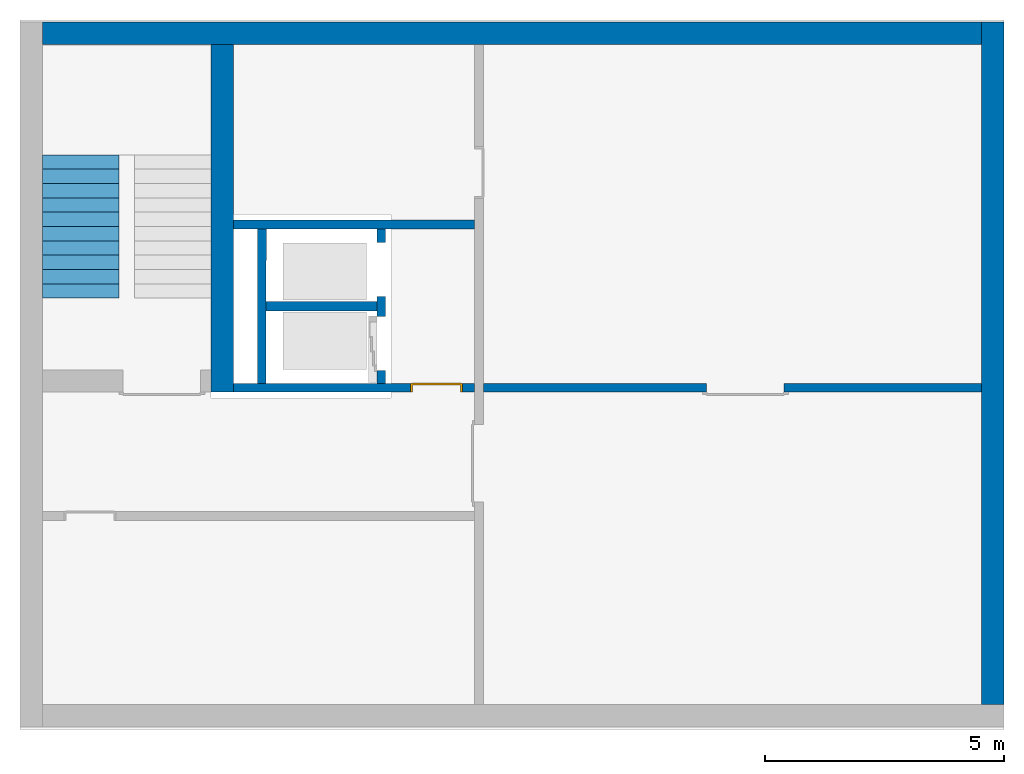
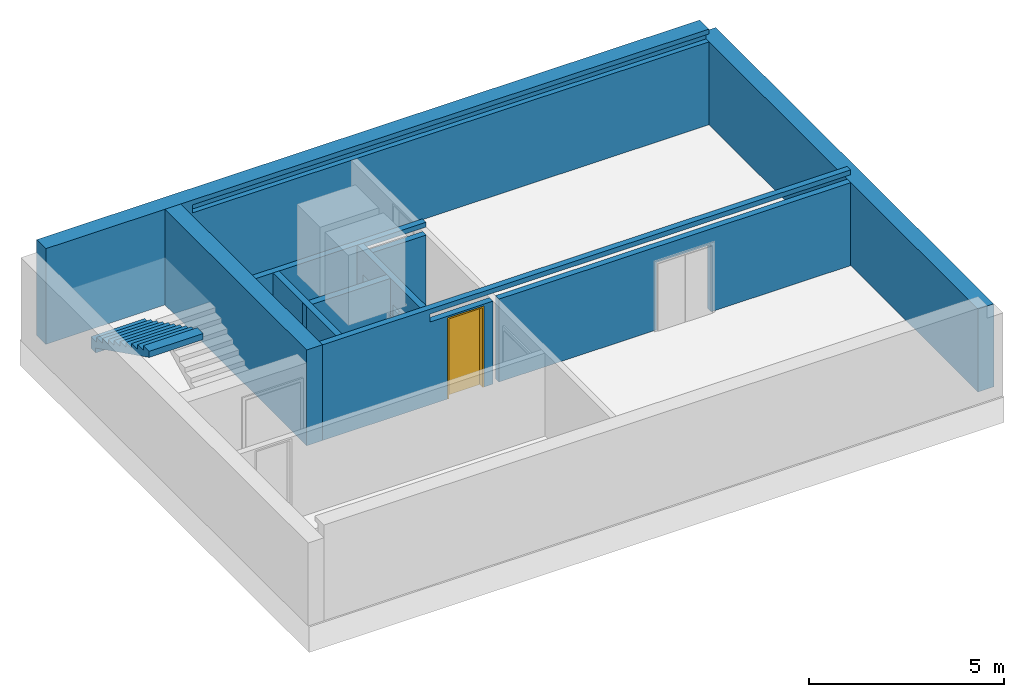
# One storey, part 2 of 5: 8 walls, 1 building element part, 1 door, 4 openings, 1 element without a shape of its own.
"""IFC4 building model written with IfcOpenShell, lengths in metres."""

from ifc_helpers import new_model, entity, si_unit, converted_unit, derived_unit, direction, frame, origin_with_axes, place, context, subcontext, project, spatial, polygons, material, type_object, element, fill, aggregate, save


model = new_model("IFC4")

# Units and contexts
model_context = context("Model", 3, precision=1e-05, world=origin_with_axes(), true_north=direction((0.0, 1.0)))
body_context = subcontext(model_context, "Body", "Model", "MODEL_VIEW")
ifc_project = project(units=[si_unit("LENGTHUNIT", "METRE"), si_unit("AREAUNIT", "SQUARE_METRE"), si_unit("VOLUMEUNIT", "CUBIC_METRE"), converted_unit("PLANEANGLEUNIT", "DEGREE", entity("IfcPlaneAngleMeasure", 0.0174532925199433), si_unit("PLANEANGLEUNIT", "RADIAN"), dimensions=[0, 0, 0, 0, 0, 0, 0]), converted_unit("TIMEUNIT", "Year", entity("IfcTimeMeasure", 31557600.0), si_unit("TIMEUNIT", "SECOND"), dimensions=[0, 0, 1, 0, 0, 0, 0]), si_unit("MASSUNIT", "GRAM", prefix="KILO"), si_unit("THERMODYNAMICTEMPERATUREUNIT", "DEGREE_CELSIUS"), si_unit("LUMINOUSINTENSITYUNIT", "LUMEN"), si_unit("ENERGYUNIT", "JOULE", prefix="MEGA"), derived_unit("THERMALCONDUCTANCEUNIT", [(si_unit("POWERUNIT", "WATT"), 1), (si_unit("LENGTHUNIT", "METRE"), -1), (si_unit("THERMODYNAMICTEMPERATUREUNIT", "KELVIN"), -1)]), derived_unit("SPECIFICHEATCAPACITYUNIT", [(si_unit("ENERGYUNIT", "JOULE"), 1), (si_unit("MASSUNIT", "GRAM", prefix="KILO"), -1), (si_unit("THERMODYNAMICTEMPERATUREUNIT", "KELVIN"), -1)]), derived_unit("MASSDENSITYUNIT", [(si_unit("MASSUNIT", "GRAM", prefix="KILO"), 1), (si_unit("VOLUMEUNIT", "CUBIC_METRE"), -1)])], contexts=[model_context])

# Site, building, storey
site_placement = place(None, origin_with_axes())
site = spatial("IfcSite", under=ifc_project, at=site_placement, CompositionType="ELEMENT")
building_placement = place(site_placement, origin_with_axes())
building = spatial("IfcBuilding", under=site, at=building_placement, CompositionType="ELEMENT")
storey_placement = place(building_placement, frame((0.0, 0.0, -3.0), z_axis=(0.0, 0.0, 1.0), x_axis=(1.0, 0.0, 0.0)))
storey = spatial("IfcBuildingStorey", under=building, at=storey_placement, Name="UG", CompositionType="ELEMENT", Elevation=-3.0)

# Walls
ifc_material_1 = material(Name="Stahlbeton")
wall_type_1 = type_object("IfcWallType", Name="Stahlbeton 470", PredefinedType="NOTDEFINED")
wall_1_placement = place(storey_placement, frame((27.988, 14.33186573724055, 0.0), z_axis=(0.0, 0.0, 1.0), x_axis=(0.0, -1.0, 0.0)))
element("IfcWall", 1, at=wall_1_placement, inside=storey, type_object=wall_type_1, material=ifc_material_1, Name="Wand-003", PredefinedType="NOTDEFINED", context=body_context, shape_type="Tessellation", body=[
    polygons([(7.276865791772996, 0.4699999999999989, 3.0), (7.276865791772996, 0.0, 3.0), (7.276865791772994, 0.0, 2.600000000000001), (7.276865791772994, 0.4699999999999989, 2.600000000000001), (0.0, 0.4699999999999989, 3.0), (0.0, 0.0, 3.0), (0.0, 0.0, 0.0), (7.276865791772994, 0.0, 0.0), (7.276865791772994, 0.4699999999999989, 0.0), (0.0, 0.4699999999999989, 0.0)], [[[1, 2, 3, 4]], [[5, 6, 2, 1]], [[6, 7, 8, 3, 2]], [[3, 8, 9, 4]], [[5, 1, 4, 9, 10]], [[6, 5, 10, 7]], [[7, 10, 9, 8]]], closed=True),
])
wall_2_placement = place(storey_placement, frame((44.114, 14.33186573724055, 0.0), z_axis=(0.0, 0.0, 1.0), x_axis=(-1.0, 0.0, 0.0)))
element("IfcWall", 2, at=wall_2_placement, inside=storey, type_object=wall_type_1, material=ifc_material_1, Name="Wand-004", PredefinedType="NOTDEFINED", context=body_context, shape_type="Tessellation", body=[
    polygons([(0.0, 0.0, 2.85), (0.0, -0.1511340162344013, 2.85), (0.0, -0.1511340162344013, 2.6), (0.0, -0.4700000000000006, 2.6), (0.0, -0.4700000000000006, 3.0), (0.0, 0.0, 3.0), (15.30599999999999, -0.1511340162344013, 2.85), (15.30599999999999, 0.0, 2.85), (15.30599999999999, -0.1511340162344013, 2.6), (0.0, 0.0, 2.6), (0.0, 0.0, 0.0), (0.0, -0.4700000000000006, 0.0), (19.656, -0.4700000000000024, 3.0), (19.656, -0.4700000000000006, 0.0), (19.656, -0.4700000000000006, 2.6), (19.656, -0.4700000000000024, 2.85), (19.656, 0.0, 3.0), (15.30599999999999, 0.0, 2.6), (19.656, 0.0, 2.85), (19.656, 0.0, 2.6), (19.656, 0.0, 0.0)], [[[1, 2, 3, 4, 5, 6]], [[7, 2, 1, 8]], [[9, 3, 2, 7]], [[4, 3, 10, 11, 12]], [[13, 5, 4, 12, 14, 15, 16]], [[6, 5, 13, 17]], [[18, 8, 1, 6, 17, 19, 20, 21, 11, 10]], [[7, 8, 18, 9]], [[18, 10, 3, 9]], [[21, 14, 12, 11]], [[14, 21, 20, 15]], [[19, 16, 15, 20]], [[16, 19, 17, 13]]], closed=True),
])
wall_3_placement = place(storey_placement, frame((44.114, 0.5199999999999996, 0.0), z_axis=(0.0, 0.0, 1.0), x_axis=(0.0, 1.0, 0.0)))
element("IfcWall", 3, at=wall_3_placement, inside=storey, type_object=wall_type_1, material=ifc_material_1, Name="Wand-003", PredefinedType="NOTDEFINED", context=body_context, shape_type="Tessellation", body=[
    polygons([(14.28186573724055, -0.4699999999999989, 2.6), (14.28186573724055, 0.0, 2.6), (0.0, 0.0, 2.6), (0.0, -0.4699999999999989, 2.6), (14.28186573724055, -0.4699999999999989, 0.0), (14.28186573724055, 0.0, 0.0), (0.0, 0.0, 0.0), (0.0, -0.4699999999999989, 0.0)], [[[1, 2, 3, 4]], [[2, 1, 5, 6]], [[2, 6, 7, 3]], [[8, 4, 3, 7]], [[5, 1, 4, 8]], [[6, 5, 8, 7]]], closed=True),
])
wall_type_2 = type_object("IfcWallType", Name="Stahlbeton 200", PredefinedType="NOTDEFINED")
wall_4_placement = place(storey_placement, frame((28.958, 8.854999945467554, 0.0), z_axis=(0.0, 0.0, 1.0), x_axis=(1.0, 0.0, 0.0)))
element("IfcWall", 4, at=wall_4_placement, inside=storey, type_object=wall_type_2, material=ifc_material_1, Name="Wand-001", PredefinedType="NOTDEFINED", context=body_context, shape_type="Tessellation", body=[
    polygons([(0.002822856202019608, 0.09999999999999964, 0.0), (0.00249458891590848, -0.09999999999999964, 0.0), (0.0, -0.09999999999999964, 0.0), (0.0, 0.09999999999999964, 0.0), (0.002822856202019608, 0.09999999999999964, 2.999999999999999), (0.00249458891590848, -0.09999999999999964, 2.999999999999999), (0.0, -0.09999999999999964, 2.999999999999999), (0.0, 0.09999999999999964, 2.999999999999999)], [[[1, 2, 3, 4]], [[2, 1, 5, 6]], [[2, 6, 7, 3]], [[8, 4, 3, 7]], [[5, 1, 4, 8]], [[6, 5, 8, 7]]], closed=True),
    polygons([(2.500000000000004, 0.09999999999999964, 0.0), (2.500000000000004, -0.09999999999999964, 0.0), (0.1824948313744201, -0.09999999999999964, 0.0), (0.1828230986605313, 0.09999999999999964, 0.0), (2.500000000000004, 0.09999999999999964, 2.999999999999999), (2.500000000000004, -0.09999999999999964, 2.999999999999999), (0.1824948313744201, -0.09999999999999964, 2.999999999999999), (0.1828230986605313, 0.09999999999999964, 2.999999999999999)], [[[1, 2, 3, 4]], [[2, 1, 5, 6]], [[2, 6, 7, 3]], [[8, 4, 3, 7]], [[5, 1, 4, 8]], [[6, 5, 8, 7]]], closed=True),
])
wall_type_3 = type_object("IfcWallType", Name="Stahlbeton 180", PredefinedType="NOTDEFINED")
wall_5_placement = place(storey_placement, frame((29.13770455944251, 7.054999945467553, 0.0), z_axis=(0.0, 0.0, 1.0), x_axis=(0.001641334219674252, 0.9999986530100825, 0.0)))
element("IfcWall", 5, at=wall_5_placement, inside=storey, type_object=wall_type_3, material=ifc_material_1, Name="Wand-001", PredefinedType="NOTDEFINED", context=body_context, shape_type="Tessellation", body=[
    polygons([(0.1797048019010141, 0.1799999999999997, 0.0), (3.419709166154229, 0.1800000000000068, 0.0), (3.420004606711725, 0.0, 0.0), (0.1800002424585117, 0.0, 0.0), (0.1797048019010141, 0.1799999999999997, 3.0), (3.419709166154229, 0.1800000000000068, 3.0), (3.420004606711725, 0.0, 3.0), (0.1800002424585117, 0.0, 3.0)], [[[1, 2, 3, 4]], [[5, 6, 2, 1]], [[7, 3, 2, 6]], [[4, 3, 7, 8]], [[8, 5, 1, 4]], [[8, 7, 6, 5]]], closed=True),
])
wall_6_placement = place(storey_placement, frame((33.505, 10.65499994546756, 0.0), z_axis=(0.0, 0.0, 1.0), x_axis=(-1.0, 0.0, 0.0)))
element("IfcWall", 6, at=wall_6_placement, inside=storey, type_object=wall_type_3, material=ifc_material_1, Name="Wand-003", PredefinedType="NOTDEFINED", context=body_context, shape_type="Tessellation", body=[
    polygons([(0.0, 0.1799999999999997, 2.999999999999999), (0.0, 0.1800000000000015, 2.849999999999999), (0.0, 0.0, 2.849999999999999), (0.0, 0.0, 2.999999999999999), (1.8669999709129, 0.1799999999999997, 2.599999999999999), (1.8669999709129, 0.1799999999999997, 2.849999999999999), (5.046999999999993, 0.1799999999999997, 2.999999999999999), (5.046999999999993, 0.1799999999999997, 0.0), (0.0, 0.1799999999999997, 0.0), (0.0, 0.1800000000000033, 2.599999999999999), (1.8669999709129, -8.862633116279994e-08, 2.849999999999999), (1.8669999709129, -8.862633116279994e-08, 2.599999999999999), (0.0, 0.0, 2.599999999999999), (0.0, 0.0, 0.0), (5.046999999999993, 0.0, 0.0), (5.046999999999993, 0.0, 2.999999999999999)], [[[1, 2, 3, 4]], [[5, 6, 2, 1, 7, 8, 9, 10]], [[6, 11, 3, 2]], [[11, 12, 13, 14, 15, 16, 4, 3]], [[4, 16, 7, 1]], [[5, 12, 11, 6]], [[8, 7, 16, 15]], [[8, 15, 14, 9]], [[14, 13, 10, 9]], [[5, 10, 13, 12]]], closed=True),
])

# Wall, openings
wall_7_placement = place(storey_placement, frame((31.63800000000001, 7.054999945467554, 0.0), z_axis=(0.0, 0.0, 1.0), x_axis=(0.0, 1.0, 0.0)))
wall_7 = element("IfcWall", 7, at=wall_7_placement, inside=storey, type_object=wall_type_3, material=ifc_material_1, Name="Wand-002", PredefinedType="NOTDEFINED", context=body_context, shape_type="Tessellation", body=[
    polygons([(2.000000000000001, 0.0, 0.0), (2.000000000000001, 0.0, 2.25), (3.13, 0.0, 2.25), (3.13, 0.0, 0.0), (3.420000000000001, 0.0, 0.0), (3.420000000000001, 0.0, 3.0), (0.1799999999999988, 0.0, 3.0), (0.1799999999999988, 0.0, 0.0), (0.450000000000002, 0.0, 0.0), (0.450000000000002, 0.0, 2.25), (1.580000000000001, 0.0, 2.25), (1.580000000000001, 0.0, 0.0), (2.000000000000003, 0.1799999999999962, 0.0), (2.000000000000003, 0.1799999999999962, 2.25), (3.130000000000002, 0.1799999999999962, 2.25), (3.130000000000002, 0.1799999999999962, 0.0), (3.420000000000003, 0.1799999999999962, 0.0), (3.420000000000003, 0.1799999999999962, 3.0), (0.1799999999999988, 0.1799999999999997, 3.0), (0.1799999999999988, 0.1799999999999997, 0.0), (0.450000000000002, 0.1799999999999997, 0.0), (0.450000000000002, 0.1799999999999997, 2.25), (1.580000000000003, 0.1799999999999997, 2.25), (1.580000000000003, 0.1799999999999997, 0.0)], [[[1, 2, 3, 4, 5, 6, 7, 8, 9, 10, 11, 12]], [[2, 1, 13, 14]], [[3, 2, 14, 15]], [[4, 3, 15, 16]], [[4, 16, 17, 5]], [[18, 6, 5, 17]], [[19, 7, 6, 18]], [[8, 7, 19, 20]], [[9, 8, 20, 21]], [[9, 21, 22, 10]], [[10, 22, 23, 11]], [[11, 23, 24, 12]], [[13, 1, 12, 24]], [[14, 13, 24, 23, 22, 21, 20, 19, 18, 17, 16, 15]]], closed=True),
])
opening_1_placement = place(wall_7_placement, frame((1.015000000000002, 0.0, 0.0), z_axis=(0.0, 0.0, 1.0), x_axis=(1.0, 0.0, 0.0)))
element("IfcOpeningElement", 8, at=opening_1_placement, cuts=wall_7, context=body_context, identifier="Reference", shape_type="Tessellation", body=[
    polygons([(-0.5649999999999995, -0.001000000000001222, 2.25), (-0.5649999999999995, -0.001000000000001222, 0.0), (0.5649999999999995, -0.001000000000001222, 0.0), (0.5649999999999995, -0.001000000000001222, 2.25), (-0.5649999999999995, 0.1810000000000045, 2.25), (-0.5649999999999995, 0.1810000000000045, 0.0), (0.5650000000000013, 0.1810000000000045, 0.0), (0.5650000000000013, 0.1810000000000045, 2.25)], [[[1, 2, 3, 4]], [[5, 6, 2, 1]], [[6, 7, 3, 2]], [[7, 8, 4, 3]], [[8, 5, 1, 4]], [[7, 6, 5, 8]]], closed=True),
])
opening_2_placement = place(wall_7_placement, frame((2.565000000000001, 0.0, 0.0), z_axis=(0.0, 0.0, 1.0), x_axis=(1.0, 0.0, 0.0)))
element("IfcOpeningElement", 9, at=opening_2_placement, cuts=wall_7, context=body_context, identifier="Reference", shape_type="Tessellation", body=[
    polygons([(-0.5649999999999995, -0.001000000000004775, 2.25), (-0.5649999999999995, -0.001000000000004775, 0.0), (0.5649999999999995, -0.001000000000004775, 0.0), (0.5649999999999995, -0.001000000000004775, 2.25), (-0.5649999999999977, 0.1810000000000009, 2.25), (-0.5649999999999977, 0.1810000000000009, 0.0), (0.5650000000000013, 0.1810000000000009, 0.0), (0.5650000000000013, 0.1810000000000009, 2.25)], [[[1, 2, 3, 4]], [[5, 6, 2, 1]], [[6, 7, 3, 2]], [[7, 8, 4, 3]], [[8, 5, 1, 4]], [[7, 6, 5, 8]]], closed=True),
])

# Wall, openings, door
wall_8_placement = place(storey_placement, frame((27.988, 7.054999945467553, 0.0), z_axis=(0.0, 0.0, 1.0), x_axis=(1.0, 0.0, 0.0)))
wall_8 = element("IfcWall", 10, at=wall_8_placement, inside=storey, type_object=wall_type_3, material=ifc_material_1, Name="Wand-001", PredefinedType="NOTDEFINED", context=body_context, shape_type="Tessellation", body=[
    polygons([(10.370657642847, 0.1799999999999997, 2.11), (10.370657642847, 0.1799999999999997, 0.0), (5.696999999999992, 0.1799999999999997, 0.0), (5.696999999999992, 0.1800000000000024, 2.599999999999999), (8.204999999999995, 0.1800000000000024, 2.599999999999999), (16.12599999999999, 0.1800000000000006, 2.599999999999999), (16.12599999999999, 0.1800000000000006, 0.0), (11.99065764284701, 0.1800000000000006, 0.0), (11.99065764284701, 0.1800000000000006, 2.11), (10.370657642847, 0.0, 2.11), (10.370657642847, 0.0, 0.0), (5.696999999999992, 0.0, 0.0), (5.696999999999992, 0.0, 2.599999999999999), (16.12599999999999, 0.0, 2.599999999999999), (16.12599999999999, 0.0, 0.0), (11.99065764284701, 0.0, 0.0), (11.99065764284701, 0.0, 2.11)], [[[1, 2, 3, 4, 5, 6, 7, 8, 9]], [[2, 1, 10, 11]], [[2, 11, 12, 3]], [[13, 4, 3, 12]], [[4, 13, 14, 6, 5]], [[6, 14, 15, 7]], [[16, 8, 7, 15]], [[9, 8, 16, 17]], [[1, 9, 17, 10]], [[17, 16, 15, 14, 13, 12, 11, 10]]], closed=True),
    polygons([(4.171999999999993, 0.1799999999999997, 2.545), (4.171999999999993, 0.1799999999999997, 0.0), (0.4699999999999989, 0.1799999999999997, 0.0), (0.4699999999999989, 0.1800000000000006, 2.999999999999999), (16.12599999999999, 0.1800000000000006, 2.999999999999999), (16.12599999999999, 0.1800000000000006, 2.849999999999999), (8.204999999999995, 0.1800000000000024, 2.849999999999999), (5.696999999999992, 0.1800000000000024, 2.849999999999999), (3.650000029087092, 0.1799999999999997, 2.849999999999999), (3.650000029087092, 0.1799999999999997, 2.599999999999999), (5.516999999999992, 0.1799999999999997, 2.599999999999999), (5.516999999999992, 0.1799999999999997, 0.0), (5.261999999999997, 0.1799999999999997, 0.0), (5.261999999999997, 0.1799999999999997, 2.545), (4.171999999999993, 1.290979261270309e-07, 2.545), (4.171999999999993, 0.0, 0.0), (0.4699999999999989, 0.0, 0.0), (0.4699999999999989, 0.0, 2.599999999999999), (0.4699999999999989, 0.0, 2.999999999999999), (16.12599999999999, 0.0, 2.999999999999999), (16.12599999999999, 0.0, 2.849999999999999), (3.650000029087092, 1.290979261270309e-07, 2.849999999999999), (3.650000029087092, 1.290979261270309e-07, 2.599999999999999), (5.516999999999992, 0.0, 2.599999999999999), (5.516999999999992, 0.0, 0.0), (5.261999999999997, 0.0, 0.0), (5.261999999999997, 1.290979261270309e-07, 2.545)], [[[1, 2, 3, 4, 5, 6, 7, 8, 9, 10, 11, 12, 13, 14]], [[2, 1, 15, 16]], [[2, 16, 17, 3]], [[3, 17, 18, 19, 4]], [[5, 4, 19, 20]], [[21, 6, 5, 20]], [[6, 21, 22, 9, 8, 7]], [[10, 9, 22, 23]], [[24, 11, 10, 23]], [[11, 24, 25, 12]], [[26, 13, 12, 25]], [[14, 13, 26, 27]], [[1, 14, 27, 15]], [[27, 26, 25, 24, 23, 22, 21, 20, 19, 18, 17, 16, 15]]], closed=True),
])
opening_3_placement = place(wall_8_placement, frame((4.716999999999995, 0.0, 0.0), z_axis=(0.0, 0.0, 1.0), x_axis=(1.0, 0.0, 0.0)))
opening_3 = element("IfcOpeningElement", 11, at=opening_3_placement, cuts=wall_8, context=body_context, identifier="Reference", shape_type="Tessellation", body=[
    polygons([(-0.5450000000000017, -0.001000000000000334, 2.545000000000001), (-0.5450000000000017, -0.001000000000000334, 0.0), (0.5450000000000017, -0.001000000000000334, 0.0), (0.5450000000000017, -0.001000000000000334, 2.545000000000001), (-0.5450000000000017, 0.181, 2.545000000000001), (-0.5450000000000017, 0.181, 0.0), (0.5450000000000017, 0.181, 0.0), (0.5450000000000017, 0.181, 2.545000000000001)], [[[1, 2, 3, 4]], [[5, 6, 2, 1]], [[6, 7, 3, 2]], [[7, 8, 4, 3]], [[8, 5, 1, 4]], [[7, 6, 5, 8]]], closed=True),
])
opening_4_placement = place(wall_8_placement, frame((11.18065764284701, 0.0, 0.0), z_axis=(0.0, 0.0, 1.0), x_axis=(1.0, 0.0, 0.0)))
element("IfcOpeningElement", 12, at=opening_4_placement, cuts=wall_8, context=body_context, identifier="Reference", shape_type="Tessellation", body=[
    polygons([(0.8100000000000023, 0.1810000000000018, 2.110000000000002), (0.8100000000000023, 0.1810000000000018, 0.0), (-0.8100000000000023, 0.1810000000000018, 0.0), (-0.8100000000000023, 0.1810000000000027, 2.110000000000002), (0.8100000000000023, -0.001000000000004775, 2.110000000000002), (0.8100000000000023, -0.001000000000004775, 0.0), (-0.8100000000000023, -0.001000000000004775, 0.0), (-0.8100000000000023, -0.001000000000003887, 2.110000000000002)], [[[1, 2, 3, 4]], [[5, 6, 2, 1]], [[6, 7, 3, 2]], [[7, 8, 4, 3]], [[8, 5, 1, 4]], [[7, 6, 5, 8]]], closed=True),
])
door_type = type_object("IfcDoorType", Name="27", OperationType="SINGLE_SWING_RIGHT", PredefinedType="DOOR")
door_placement = place(opening_3_placement, frame((-0.5, 0.0, 0.0), z_axis=(0.0, 0.0, 1.0), x_axis=(1.0, 0.0, 0.0)))
door = element("IfcDoor", 13, at=door_placement, inside=storey, type_object=door_type, OverallHeight=2.545, OverallWidth=1.09, PredefinedType="DOOR", context=body_context, shape_type="Tessellation", body=[
    polygons([(1.045000000000002, 0.0, 0.0), (1.045000000000002, 0.1549999999999994, 0.0), (1.045000000000002, 0.1550000000000002, 2.545000000000001), (1.045000000000002, 0.0, 2.545000000000001), (1.0, 0.0, 0.0), (1.0, 0.1549999999999994, 0.0), (1.0, 0.1550000000000002, 2.500000000000001), (0.555100000000003, 0.1550000000000002, 2.500000000000001), (0.5001000000000033, 0.1550000000000002, 2.500000000000001), (0.0, 0.1550000000000002, 2.500000000000001), (0.0, 0.1549999999999994, 0.0), (-0.04500000000000171, 0.1549999999999994, 0.0), (-0.04500000000000171, 0.1550000000000002, 2.545000000000001), (-0.04500000000000171, 0.0, 2.545000000000001), (-0.04500000000000171, 0.0, 0.0), (0.0, 0.0, 0.0), (0.0, 0.0, 2.500000000000001), (0.5001000000000033, 0.0, 2.500000000000001), (0.555100000000003, 0.0, 2.500000000000001), (1.0, 0.0, 2.500000000000001)], [[[1, 2, 3, 4]], [[5, 6, 2, 1]], [[2, 6, 7, 8, 9, 10, 11, 12, 13, 3]], [[4, 3, 13, 14]], [[1, 4, 14, 15, 16, 17, 18, 19, 20, 5]], [[20, 7, 6, 5]], [[19, 8, 7, 20]], [[18, 9, 8, 19]], [[17, 10, 9, 18]], [[16, 11, 10, 17]], [[15, 12, 11, 16]], [[14, 13, 12, 15]]], closed=True),
    polygons([(1.045000000000002, 0.1549999999999994, 0.0), (1.045000000000002, 0.1799999999999997, 0.0), (1.045000000000002, 0.1799999999999997, 2.545000000000001), (1.045000000000002, 0.1550000000000002, 2.545000000000001), (1.009999999999998, 0.1549999999999994, 0.0), (1.009999999999998, 0.1799999999999997, 0.0), (1.009999999999998, 0.1799999999999997, 2.510000000000001), (0.5450999999999979, 0.1799999999999997, 2.510000000000001), (0.5101000000000013, 0.1799999999999997, 2.510000000000001), (-0.00999999999999801, 0.1799999999999997, 2.510000000000001), (-0.00999999999999801, 0.1799999999999997, 0.0), (-0.04500000000000171, 0.1799999999999997, 0.0), (-0.04500000000000171, 0.1799999999999997, 2.545000000000001), (-0.04500000000000171, 0.1550000000000002, 2.545000000000001), (-0.04500000000000171, 0.1549999999999994, 0.0), (-0.00999999999999801, 0.1549999999999994, 0.0), (-0.00999999999999801, 0.1550000000000002, 2.510000000000001), (0.5101000000000013, 0.1550000000000002, 2.510000000000001), (0.5450999999999979, 0.1550000000000002, 2.510000000000001), (1.009999999999998, 0.1550000000000002, 2.510000000000001)], [[[1, 2, 3, 4]], [[5, 6, 2, 1]], [[2, 6, 7, 8, 9, 10, 11, 12, 13, 3]], [[4, 3, 13, 14]], [[1, 4, 14, 15, 16, 17, 18, 19, 20, 5]], [[20, 7, 6, 5]], [[19, 8, 7, 20]], [[18, 9, 8, 19]], [[17, 10, 9, 18]], [[16, 11, 10, 17]], [[15, 12, 11, 16]], [[14, 13, 12, 15]]], closed=True),
    polygons([(1.009999999999998, 0.1949999999999994, 0.0), (-0.00999999999999801, 0.1949999999999994, 0.0), (-0.00999999999999801, 0.1950000000000003, 2.510000000000001), (1.009999999999998, 0.1950000000000003, 2.510000000000001), (1.009999999999998, 0.1549999999999994, 0.0), (-0.00999999999999801, 0.1549999999999994, 0.0), (-0.00999999999999801, 0.1550000000000002, 2.510000000000001), (1.009999999999998, 0.1550000000000002, 2.510000000000001)], [[[1, 2, 3, 4]], [[2, 1, 5, 6]], [[3, 2, 6, 7]], [[4, 3, 7, 8]], [[1, 4, 8, 5]], [[6, 5, 8, 7]]], closed=True),
])
fill(opening_3, door)

# Stair, building element part
stair_type = type_object("IfcStairType", PredefinedType="NOTDEFINED")
stair_placement = place(storey_placement, frame((24.458, 12.02499994546755, 1.5), z_axis=(0.0, 0.0, 1.0), x_axis=(1.0, 0.0, 0.0)))
stair = element("IfcStair", 14, at=stair_placement, inside=storey, type_object=stair_type, Name="Treppe - 003", PredefinedType="NOTDEFINED")
ifc_material_2 = material(Name="Stahlbeton Decke")
building_element_part_placement = place(stair_placement, origin_with_axes())
building_element_part = element("IfcBuildingElementPart", 15, at=building_element_part_placement, material=ifc_material_2, Name="Stahlbeton Decke", PredefinedType="NOTDEFINED", context=body_context, shape_type="Tessellation", body=[
    polygons([(1.600000000000001, 0.0, 0.1499999999999999), (1.600000000000001, 0.0, -0.1900657780874822), (0.0, 0.0, -0.1900657780874822), (0.0, 0.0, 0.1499999999999999), (1.600000000000001, 0.0, -0.22), (1.600000000000001, -0.2999999999999989, 0.1499999999999999), (1.600000000000001, -0.2999999999999989, 0.3), (1.600000000000001, -0.5999999999999996, 0.3), (1.600000000000001, -0.5999999999999996, 0.45), (1.600000000000001, -0.8999999999999986, 0.45), (1.600000000000001, -0.8999999999999986, 0.6000000000000001), (1.600000000000001, -1.199999999999999, 0.6000000000000001), (1.600000000000001, -1.199999999999999, 0.75), (1.600000000000001, -1.5, 0.75), (1.600000000000001, -1.5, 0.8999999999999999), (1.600000000000001, -1.800000000000001, 0.9000000000000001), (1.600000000000001, -1.800000000000001, 1.05), (1.600000000000001, -2.1, 1.05), (1.600000000000001, -2.1, 1.2), (1.600000000000001, -2.4, 1.2), (1.600000000000001, -2.4, 1.35), (1.600000000000001, -2.699999999999999, 1.35), (1.600000000000001, -2.699999999999999, 1.5), (1.600000000000001, -3.000000000000002, 1.5), (1.600000000000001, -3.000000000000002, 1.309934221912518), (1.600000000000001, -2.925000000000001, 1.272434221912518), (1.600000000000001, -2.85, 1.234934221912518), (1.600000000000001, -2.775, 1.197434221912518), (1.600000000000001, -2.699999999999999, 1.159934221912518), (1.600000000000001, -2.6, 1.109934221912517), (1.600000000000001, -2.5, 1.059934221912518), (1.600000000000001, -2.4, 1.009934221912518), (1.600000000000001, -2.299999999999999, 0.9599342219125175), (1.600000000000001, -2.199999999999999, 0.9099342219125178), (1.600000000000001, -2.1, 0.8599342219125179), (1.600000000000001, -2.0, 0.8099342219125178), (1.600000000000001, -1.9, 0.7599342219125179), (1.600000000000001, -1.800000000000001, 0.7099342219125179), (1.600000000000001, -1.725, 0.6724342219125179), (1.600000000000001, -1.65, 0.6349342219125178), (1.600000000000001, -1.574999999999999, 0.5974342219125177), (1.600000000000001, -1.5, 0.5599342219125177), (1.600000000000001, -1.425000000000001, 0.5224342219125178), (1.600000000000001, -1.35, 0.4849342219125179), (1.600000000000001, -1.275, 0.4474342219125178), (1.600000000000001, -1.199999999999999, 0.4099342219125179), (1.600000000000001, -1.125, 0.3724342219125178), (1.600000000000001, -1.049999999999999, 0.3349342219125178), (1.600000000000001, -0.9749999999999996, 0.2974342219125179), (1.600000000000001, -0.8999999999999986, 0.2599342219125178), (1.600000000000001, -0.7999999999999989, 0.2099342219125178), (1.600000000000001, -0.6999999999999993, 0.1599342219125177), (1.600000000000001, -0.5999999999999996, 0.1099342219125177), (1.600000000000001, -0.5, 0.05993422191251785), (1.600000000000001, -0.4000000000000004, 0.009934221912517804), (1.600000000000001, -0.2999999999999989, -0.04006577808748224), (1.600000000000001, -0.25, -0.06506577808748215), (1.600000000000001, -0.25, -0.22), (0.0, 0.0, -0.22), (0.0, -0.25, -0.22), (0.0, -0.25, -0.06506577808748215), (0.0, -0.2999999999999989, -0.04006577808748224), (0.0, -0.4000000000000004, 0.009934221912517804), (0.0, -0.5, 0.05993422191251785), (0.0, -0.5999999999999996, 0.1099342219125177), (0.0, -0.6999999999999993, 0.1599342219125177), (0.0, -0.7999999999999989, 0.2099342219125178), (0.0, -0.8999999999999986, 0.2599342219125178), (0.0, -0.9749999999999996, 0.2974342219125179), (0.0, -1.049999999999999, 0.3349342219125178), (0.0, -1.125, 0.3724342219125178), (0.0, -1.199999999999999, 0.4099342219125179), (0.0, -1.275, 0.4474342219125178), (0.0, -1.35, 0.4849342219125179), (0.0, -1.425000000000001, 0.5224342219125178), (0.0, -1.5, 0.5599342219125177), (0.0, -1.574999999999999, 0.5974342219125177), (0.0, -1.65, 0.6349342219125178), (0.0, -1.725, 0.6724342219125179), (0.0, -1.800000000000001, 0.7099342219125179), (0.0, -1.9, 0.7599342219125179), (0.0, -2.0, 0.8099342219125178), (0.0, -2.1, 0.8599342219125179), (0.0, -2.199999999999999, 0.9099342219125178), (0.0, -2.299999999999999, 0.9599342219125175), (0.0, -2.4, 1.009934221912518), (0.0, -2.5, 1.059934221912518), (0.0, -2.6, 1.109934221912517), (0.0, -2.699999999999999, 1.159934221912518), (0.0, -2.775, 1.197434221912518), (0.0, -2.85, 1.234934221912518), (0.0, -2.925000000000001, 1.272434221912518), (0.0, -3.000000000000002, 1.309934221912518), (0.0, -3.000000000000002, 1.5), (0.0, -2.699999999999999, 1.5), (0.0, -2.699999999999999, 1.35), (0.0, -2.4, 1.35), (0.0, -2.4, 1.2), (0.0, -2.1, 1.2), (0.0, -2.1, 1.05), (0.0, -1.800000000000001, 1.05), (0.0, -1.800000000000001, 0.8999999999999999), (0.0, -1.5, 0.8999999999999999), (0.0, -1.5, 0.75), (0.0, -1.199999999999999, 0.75), (0.0, -1.199999999999999, 0.6000000000000001), (0.0, -0.8999999999999986, 0.6000000000000001), (0.0, -0.8999999999999986, 0.45), (0.0, -0.5999999999999996, 0.45), (0.0, -0.5999999999999996, 0.2999999999999998), (0.0, -0.2999999999999989, 0.3), (0.0, -0.2999999999999989, 0.1499999999999999)], [[[1, 2, 3, 4]], [[5, 2, 1, 6, 7, 8, 9, 10, 11, 12, 13, 14, 15, 16, 17, 18, 19, 20, 21, 22, 23, 24, 25, 26, 27, 28, 29, 30, 31, 32, 33, 34, 35, 36, 37, 38, 39, 40, 41, 42, 43, 44, 45, 46, 47, 48, 49, 50, 51, 52, 53, 54, 55, 56, 57, 58]], [[59, 3, 2, 5]], [[60, 61, 62, 63, 64, 65, 66, 67, 68, 69, 70, 71, 72, 73, 74, 75, 76, 77, 78, 79, 80, 81, 82, 83, 84, 85, 86, 87, 88, 89, 90, 91, 92, 93, 94, 95, 96, 97, 98, 99, 100, 101, 102, 103, 104, 105, 106, 107, 108, 109, 110, 111, 112, 4, 3, 59]], [[6, 1, 4, 112]], [[112, 111, 7, 6]], [[8, 7, 111, 110]], [[110, 109, 9, 8]], [[10, 9, 109, 108]], [[108, 107, 11, 10]], [[12, 11, 107, 106]], [[106, 105, 13, 12]], [[14, 13, 105, 104]], [[104, 103, 15, 14]], [[16, 15, 103, 102]], [[102, 101, 17, 16]], [[18, 17, 101, 100]], [[100, 99, 19, 18]], [[20, 19, 99, 98]], [[98, 97, 21, 20]], [[22, 21, 97, 96]], [[96, 95, 23, 22]], [[95, 94, 24, 23]], [[24, 94, 93, 25]], [[26, 25, 93, 92]], [[27, 26, 92, 91]], [[28, 27, 91, 90]], [[29, 28, 90, 89]], [[30, 29, 89, 88]], [[31, 30, 88, 87]], [[32, 31, 87, 86]], [[33, 32, 86, 85]], [[34, 33, 85, 84]], [[35, 34, 84, 83]], [[36, 35, 83, 82]], [[37, 36, 82, 81]], [[38, 37, 81, 80]], [[39, 38, 80, 79]], [[40, 39, 79, 78]], [[41, 40, 78, 77]], [[42, 41, 77, 76]], [[43, 42, 76, 75]], [[44, 43, 75, 74]], [[45, 44, 74, 73]], [[46, 45, 73, 72]], [[47, 46, 72, 71]], [[48, 47, 71, 70]], [[49, 48, 70, 69]], [[50, 49, 69, 68]], [[51, 50, 68, 67]], [[52, 51, 67, 66]], [[53, 52, 66, 65]], [[54, 53, 65, 64]], [[55, 54, 64, 63]], [[56, 55, 63, 62]], [[62, 61, 57, 56]], [[58, 57, 61, 60]], [[58, 60, 59, 5]]], closed=True),
])
aggregate(stair, [building_element_part])

save(model, "model.ifc")
